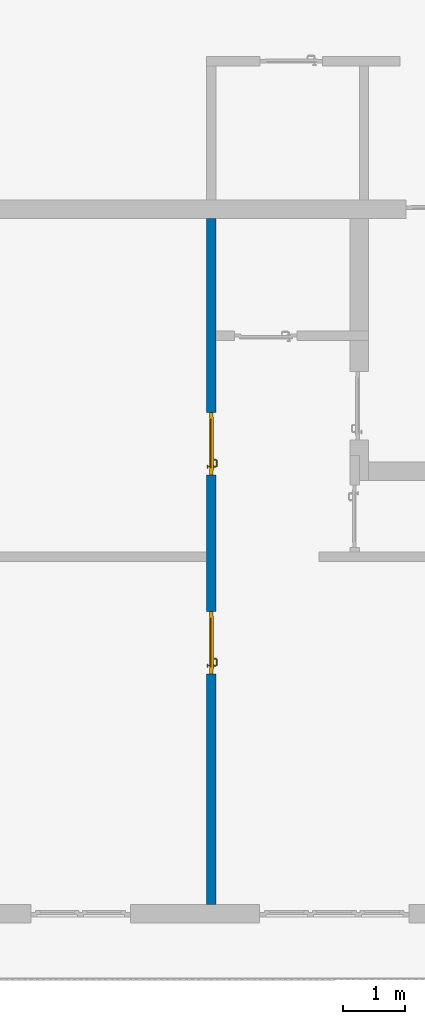
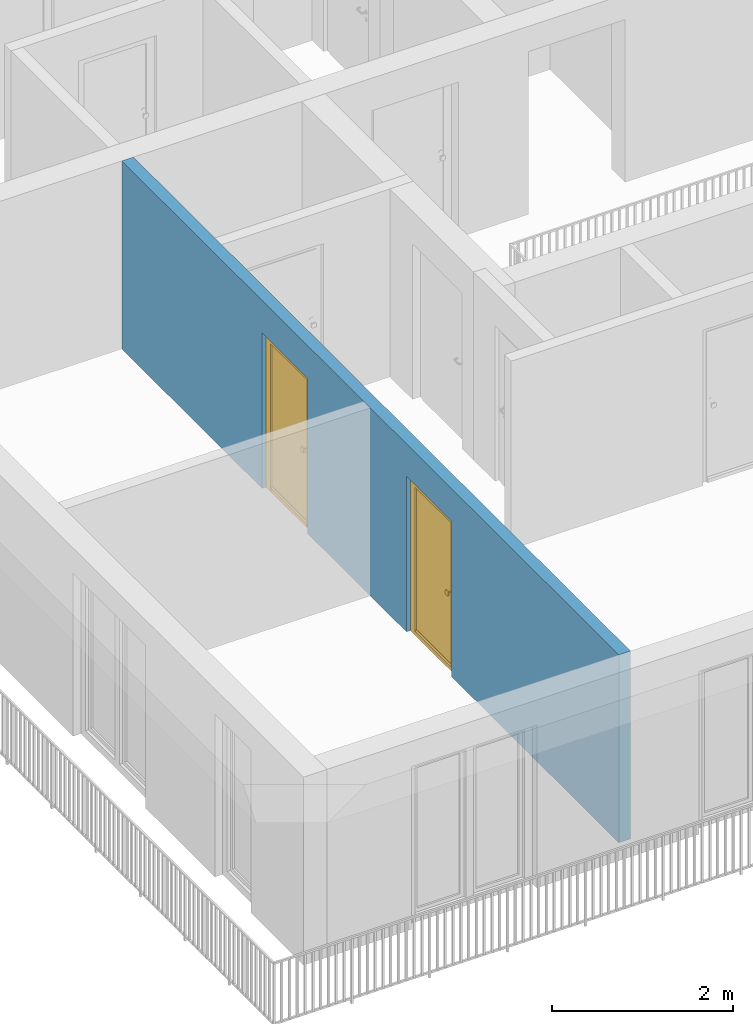
# One storey, part 8 of 54: 2 doors, 1 wall, 2 openings.
"""IFC4 building model written with IfcOpenShell, lengths in metres."""

from ifc_helpers import new_model, entity, si_unit, converted_unit, derived_unit, direction, frame, origin_with_axes, place, context, subcontext, project, spatial, polygons, source, transform, mapped, material, type_object, element, fill, save


model = new_model("IFC4")

# Units and contexts
model_context = context("Model", 3, precision=1e-05, world=origin_with_axes(), true_north=direction((0.0, 1.0)))
body_context = subcontext(model_context, "Body", "Model", "MODEL_VIEW")
ifc_project = project(units=[si_unit("LENGTHUNIT", "METRE"), si_unit("AREAUNIT", "SQUARE_METRE"), si_unit("VOLUMEUNIT", "CUBIC_METRE"), converted_unit("PLANEANGLEUNIT", "DEGREE", entity("IfcPlaneAngleMeasure", 0.0174532925199), si_unit("PLANEANGLEUNIT", "RADIAN"), dimensions=[0, 0, 0, 0, 0, 0, 0]), converted_unit("TIMEUNIT", "Year", entity("IfcTimeMeasure", 31556926.0), si_unit("TIMEUNIT", "SECOND"), dimensions=[0, 0, 1, 0, 0, 0, 0]), si_unit("MASSUNIT", "GRAM", prefix="KILO"), si_unit("THERMODYNAMICTEMPERATUREUNIT", "DEGREE_CELSIUS"), si_unit("LUMINOUSINTENSITYUNIT", "LUMEN"), si_unit("ENERGYUNIT", "JOULE", prefix="MEGA"), derived_unit("THERMALCONDUCTANCEUNIT", [(si_unit("POWERUNIT", "WATT"), 1), (si_unit("LENGTHUNIT", "METRE"), -1), (si_unit("THERMODYNAMICTEMPERATUREUNIT", "KELVIN"), -1)]), derived_unit("SPECIFICHEATCAPACITYUNIT", [(si_unit("ENERGYUNIT", "JOULE"), 1), (si_unit("MASSUNIT", "GRAM", prefix="KILO"), -1), (si_unit("THERMODYNAMICTEMPERATUREUNIT", "KELVIN"), -1)]), derived_unit("MASSDENSITYUNIT", [(si_unit("MASSUNIT", "GRAM", prefix="KILO"), 1), (si_unit("VOLUMEUNIT", "CUBIC_METRE"), -1)])], contexts=[model_context])

# Site, building, storey
site_placement = place(None, origin_with_axes())
site = spatial("IfcSite", under=ifc_project, at=site_placement, CompositionType="ELEMENT")
building_placement = place(site_placement, origin_with_axes())
building = spatial("IfcBuilding", under=site, at=building_placement, CompositionType="ELEMENT")
storey_placement = place(building_placement, frame((0.0, 0.0, 9.18), z_axis=(0.0, 0.0, 1.0), x_axis=(1.0, 0.0, 0.0)))
storey = spatial("IfcBuildingStorey", under=building, at=storey_placement, Name="3. Geschoss", CompositionType="ELEMENT", Elevation=9.18)

# Wall, openings, doors
ifc_material = material()
wall_type = type_object("IfcWallType", Name="150", PredefinedType="NOTDEFINED")
wall_placement = place(storey_placement, frame((-7.5421993804, 1.37118776896, 0.0), z_axis=(0.0, 0.0, 1.0), x_axis=(0.0, -1.0, 0.0)))
wall = element("IfcWall", 1, at=wall_placement, inside=storey, type_object=wall_type, material=ifc_material, Name="Wand-003", PredefinedType="NOTDEFINED", context=body_context, shape_type="Tessellation", body=[
    polygons([(7.3, 0.15, 0.0), (7.3, 0.15, 2.1), (6.3, 0.15, 2.1), (6.3, 0.15, 0.0), (4.1078818937, 0.15, 0.0), (4.1078818937, 0.15, 2.1), (3.1078818937, 0.15, 2.1), (3.1078818937, 0.15, 0.0), (0.0, 0.15, 0.0), (0.0, 0.15, 2.54), (11.0, 0.15, 2.54), (11.0, 0.15, 0.0), (7.3, 0.05, 0.0), (7.3, 0.0, 0.0), (7.3, 0.0, 2.1), (6.3, 0.0, 2.1), (6.3, 0.05, 0.0), (6.3, 0.0, 0.0), (4.1078818937, 0.0, 0.0), (4.1078818937, 0.0, 2.1), (3.1078818937, 0.0, 2.1), (3.1078818937, 0.0, 0.0), (0.0, 0.0, 0.0), (0.0, 0.0, 2.54), (11.0, 0.0, 2.54), (11.0, 0.0, 0.0)], [[[1, 2, 3, 4, 5, 6, 7, 8, 9, 10, 11, 12]], [[2, 1, 13, 14, 15]], [[3, 2, 15, 16]], [[17, 4, 3, 16, 18]], [[4, 17, 18, 19, 5]], [[19, 20, 6, 5]], [[20, 21, 7, 6]], [[21, 22, 8, 7]], [[23, 9, 8, 22]], [[23, 24, 10, 9]], [[25, 11, 10, 24]], [[12, 11, 25, 26]], [[13, 1, 12, 26, 14]], [[19, 18, 16, 15, 14, 26, 25, 24, 23, 22, 21, 20]]], closed=True),
])
opening_1_placement = place(wall_placement, frame((3.6078818937, 0.0, 0.0), z_axis=(0.0, 0.0, 1.0), x_axis=(1.0, 0.0, 0.0)))
opening_1 = element("IfcOpeningElement", 2, at=opening_1_placement, cuts=wall, context=body_context, identifier="Reference", shape_type="Tessellation", body=[
    polygons([(0.5, 0.05, 0.0), (0.5, 0.05, 2.1), (0.5, -0.001, 2.1), (0.5, -0.001, 0.0), (0.5, 0.151, 0.0), (0.5, 0.151, 2.1), (-0.5, 0.05, 2.1), (-0.5, -0.001, 2.1), (-0.5, 0.151, 2.1), (-0.5, -0.001, 0.0), (-0.5, 0.05, 0.0), (-0.5, 0.151, 0.0)], [[[1, 2, 3, 4]], [[2, 1, 5, 6]], [[7, 8, 3, 2, 6, 9]], [[8, 10, 4, 3]], [[1, 4, 10, 11, 12, 5]], [[6, 5, 12, 9]], [[7, 11, 10, 8]], [[11, 7, 9, 12]]], closed=True),
])
opening_2_placement = place(wall_placement, frame((6.8, 0.0, 0.0), z_axis=(0.0, 0.0, 1.0), x_axis=(1.0, 0.0, 0.0)))
opening_2 = element("IfcOpeningElement", 3, at=opening_2_placement, cuts=wall, context=body_context, identifier="Reference", shape_type="Tessellation", body=[
    polygons([(0.5, 0.05, 0.0), (0.5, 0.05, 2.1), (0.5, -0.001, 2.1), (0.5, -0.001, 0.0), (0.5, 0.151, 0.0), (0.5, 0.151, 2.1), (-0.5, 0.05, 2.1), (-0.5, -0.001, 2.1), (-0.5, 0.151, 2.1), (-0.5, -0.001, 0.0), (-0.5, 0.05, 0.0), (-0.5, 0.151, 0.0)], [[[1, 2, 3, 4]], [[2, 1, 5, 6]], [[7, 8, 3, 2, 6, 9]], [[8, 10, 4, 3]], [[1, 4, 10, 11, 12, 5]], [[6, 5, 12, 9]], [[7, 11, 10, 8]], [[11, 7, 9, 12]]], closed=True),
])
door_type = type_object("IfcDoorType", Name="Eingang 01 1-Fl 26", OperationType="SINGLE_SWING_LEFT", PredefinedType="DOOR")
shared_shape = source(origin_with_axes(), body_context, "Body", "Tessellation", [
    polygons([(-0.5, -0.05, 0.0), (-0.5, -0.05, 2.1), (-0.5, -0.03, 2.1), (-0.5, -0.03, 0.0), (-0.4, -0.05, 0.0), (-0.4, -0.05, 2.0), (-0.1301, -0.05, 2.0), (-0.0001, -0.05, 2.0), (0.4, -0.05, 2.0), (0.4, -0.05, 0.0), (0.5, -0.05, 0.0), (0.5, -0.05, 2.1), (0.5, -0.03, 2.1), (0.5, -0.03, 0.0), (0.4, -0.03, 0.0), (0.4, -0.03, 2.0), (-0.0001, -0.03, 2.0), (-0.1301, -0.03, 2.0), (-0.4, -0.03, 2.0), (-0.4, -0.03, 0.0)], [[[1, 2, 3, 4]], [[1, 5, 6, 7, 8, 9, 10, 11, 12, 2]], [[2, 12, 13, 3]], [[4, 3, 13, 14, 15, 16, 17, 18, 19, 20]], [[5, 1, 4, 20]], [[6, 5, 20, 19]], [[7, 6, 19, 18]], [[8, 7, 18, 17]], [[9, 8, 17, 16]], [[10, 9, 16, 15]], [[11, 10, 15, 14]], [[12, 11, 14, 13]]], closed=True),
    polygons([(-0.5, -0.03, 0.0), (-0.5, -0.03, 2.1), (-0.5, 0.0, 2.1), (-0.5, 0.0, 0.0), (-0.43, -0.03, 0.0), (-0.43, -0.03, 2.03), (-0.1001, -0.03, 2.03), (-0.0301, -0.03, 2.03), (0.43, -0.03, 2.03), (0.43, -0.03, 0.0), (0.5, -0.03, 0.0), (0.5, -0.03, 2.1), (0.5, 0.0, 2.1), (0.5, 0.0, 0.0), (0.43, 0.0, 0.0), (0.43, 0.0, 2.03), (-0.0301, 0.0, 2.03), (-0.1001, 0.0, 2.03), (-0.43, 0.0, 2.03), (-0.43, 0.0, 0.0)], [[[1, 2, 3, 4]], [[1, 5, 6, 7, 8, 9, 10, 11, 12, 2]], [[2, 12, 13, 3]], [[4, 3, 13, 14, 15, 16, 17, 18, 19, 20]], [[5, 1, 4, 20]], [[6, 5, 20, 19]], [[7, 6, 19, 18]], [[8, 7, 18, 17]], [[9, 8, 17, 16]], [[10, 9, 16, 15]], [[11, 10, 15, 14]], [[12, 11, 14, 13]]], closed=True),
    polygons([(-0.43, 0.01, 0.0), (-0.43, 0.01, 2.03), (0.43, 0.01, 2.03), (0.43, 0.01, 0.0), (-0.43, -0.03, 0.0), (-0.43, -0.03, 2.03), (0.43, -0.03, 2.03), (0.43, -0.03, 0.0)], [[[1, 2, 3, 4]], [[1, 5, 6, 2]], [[2, 6, 7, 3]], [[3, 7, 8, 4]], [[4, 8, 5, 1]], [[8, 7, 6, 5]]], closed=True),
    polygons([(-0.395, -0.05, 0.0), (0.395, -0.05, 0.0), (0.395, -0.05, 0.05), (-0.395, -0.05, 0.05), (-0.395, -0.03, 0.0), (0.395, -0.03, 0.0), (0.395, -0.03, 0.07), (0.395, -0.035, 0.07), (-0.395, -0.035, 0.07), (-0.395, -0.03, 0.07)], [[[1, 2, 3, 4]], [[5, 6, 2, 1]], [[2, 6, 7, 8, 3]], [[4, 3, 8, 9]], [[1, 4, 9, 10, 5]], [[10, 7, 6, 5]], [[9, 8, 7, 10]]], closed=True),
    polygons([(0.3835, 0.02, 1.0733826859), (0.37, 0.02, 1.077), (0.37, 0.0199, 1.077), (0.3835, 0.0199, 1.0733826859), (0.393382685902, 0.02, 1.0635), (0.397, 0.02, 1.05), (0.393382685902, 0.02, 1.0365), (0.3835, 0.02, 1.0266173141), (0.37, 0.02, 1.023), (0.3565, 0.02, 1.0266173141), (0.346617314098, 0.02, 1.0365), (0.343, 0.02, 1.05), (0.346617314098, 0.02, 1.0635), (0.3565, 0.02, 1.0733826859), (0.3565, 0.0199, 1.0733826859), (0.37, 0.0101, 1.077), (0.3835, 0.0101, 1.0733826859), (0.393382685902, 0.0199, 1.0635), (0.397, 0.0199, 1.05), (0.393382685902, 0.0199, 1.0365), (0.3835, 0.0199, 1.0266173141), (0.37, 0.0199, 1.023), (0.3565, 0.0199, 1.0266173141), (0.346617314098, 0.0199, 1.0365), (0.343, 0.0199, 1.05), (0.346617314098, 0.0199, 1.0635), (0.3565, 0.0101, 1.0733826859), (0.37, 0.01, 1.077), (0.3835, 0.01, 1.0733826859), (0.393382685902, 0.0101, 1.0635), (0.397, 0.0101, 1.05), (0.393382685902, 0.0101, 1.0365), (0.3835, 0.0101, 1.0266173141), (0.37, 0.0101, 1.023), (0.3565, 0.0101, 1.0266173141), (0.346617314098, 0.0101, 1.0365), (0.343, 0.0101, 1.05), (0.346617314098, 0.0101, 1.0635), (0.3565, 0.01, 1.0733826859), (0.346617314098, 0.01, 1.0635), (0.343, 0.01, 1.05), (0.346617314098, 0.01, 1.0365), (0.3565, 0.01, 1.0266173141), (0.37, 0.01, 1.023), (0.3835, 0.01, 1.0266173141), (0.393382685902, 0.01, 1.0365), (0.397, 0.01, 1.05), (0.393382685902, 0.01, 1.0635)], [[[1, 2, 3, 4]], [[2, 1, 5, 6, 7, 8, 9, 10, 11, 12, 13, 14]], [[2, 14, 15, 3]], [[4, 3, 16, 17]], [[5, 1, 4, 18]], [[6, 5, 18, 19]], [[7, 6, 19, 20]], [[8, 7, 20, 21]], [[9, 8, 21, 22]], [[10, 9, 22, 23]], [[11, 10, 23, 24]], [[12, 11, 24, 25]], [[13, 12, 25, 26]], [[14, 13, 26, 15]], [[3, 15, 27, 16]], [[17, 16, 28, 29]], [[18, 4, 17, 30]], [[19, 18, 30, 31]], [[20, 19, 31, 32]], [[21, 20, 32, 33]], [[22, 21, 33, 34]], [[23, 22, 34, 35]], [[24, 23, 35, 36]], [[25, 24, 36, 37]], [[26, 25, 37, 38]], [[15, 26, 38, 27]], [[16, 27, 39, 28]], [[28, 39, 40, 41, 42, 43, 44, 45, 46, 47, 48, 29]], [[30, 17, 29, 48]], [[31, 30, 48, 47]], [[32, 31, 47, 46]], [[33, 32, 46, 45]], [[34, 33, 45, 44]], [[35, 34, 44, 43]], [[36, 35, 43, 42]], [[37, 36, 42, 41]], [[38, 37, 41, 40]], [[27, 38, 40, 39]]], closed=True),
    polygons([(0.362532169224, 0.019, 0.959692280177), (0.363279754556, 0.019, 0.961639806549), (0.35705, 0.019, 0.972430057958), (0.347569942042, 0.019, 0.96295), (0.365, 0.019, 0.952886751346), (0.365, 0.019, 0.9544), (0.362532169224, 0.02, 0.959692280177), (0.363279754556, 0.02, 0.961639806549), (0.364624817685, 0.02, 0.965143815798), (0.364624817685, 0.019, 0.965143815798), (0.37, 0.019, 0.967425445323), (0.37, 0.019, 0.9759), (0.357, 0.019, 0.972516660498), (0.347483339502, 0.019, 0.963), (0.365, 0.019, 0.95), (0.3441, 0.019, 0.95), (0.365, 0.019, 0.947113248654), (0.365, 0.019, 0.941339745962), (0.365, 0.019, 0.9375), (0.365, 0.02, 0.9375), (0.365, 0.02, 0.941339745962), (0.365, 0.02, 0.947113248654), (0.365, 0.02, 0.95), (0.365, 0.02, 0.952886751346), (0.365, 0.02, 0.9544), (0.346703916638, 0.02, 0.96345), (0.35655, 0.02, 0.973296083362), (0.37, 0.02, 0.9769), (0.37, 0.02, 0.967425445323), (0.375375182315, 0.019, 0.965143815798), (0.376720245444, 0.019, 0.961639806549), (0.38295, 0.019, 0.972430057958), (0.37, 0.019, 0.976), (0.357, 0.0189, 0.972516660498), (0.347483339502, 0.0189, 0.963), (0.344, 0.019, 0.95), (0.347569942042, 0.019, 0.93705), (0.35705, 0.019, 0.927569942042), (0.37, 0.019, 0.9241), (0.37, 0.019, 0.9325), (0.366464466094, 0.019, 0.933964466094), (0.366464466094, 0.02, 0.933964466094), (0.37, 0.02, 0.9231), (0.35655, 0.02, 0.926703916638), (0.37, 0.02, 0.9325), (0.346703916638, 0.02, 0.93655), (0.3431, 0.02, 0.95), (0.346617314098, 0.02, 0.9635), (0.3565, 0.02, 0.973382685902), (0.37, 0.02, 0.977), (0.375375182315, 0.02, 0.965143815798), (0.38345, 0.02, 0.973296083362), (0.376720245444, 0.02, 0.961639806549), (0.377467830776, 0.02, 0.959692280177), (0.377467830776, 0.019, 0.959692280177), (0.375, 0.019, 0.9544), (0.375, 0.019, 0.952886751346), (0.392430057958, 0.019, 0.96295), (0.383, 0.019, 0.972516660498), (0.37, 0.0189, 0.976), (0.357, 0.0101, 0.972516660498), (0.347483339502, 0.0101, 0.963), (0.344, 0.0189, 0.95), (0.347483339502, 0.019, 0.937), (0.357, 0.019, 0.927483339502), (0.37, 0.019, 0.924), (0.38295, 0.019, 0.927569942042), (0.375, 0.019, 0.941339745962), (0.375, 0.019, 0.9375), (0.373535533906, 0.019, 0.933964466094), (0.37, 0.02, 0.923), (0.3565, 0.02, 0.926617314098), (0.38345, 0.02, 0.926703916638), (0.373535533906, 0.02, 0.933964466094), (0.375, 0.02, 0.9375), (0.375, 0.02, 0.941339745962), (0.346617314098, 0.02, 0.9365), (0.343, 0.02, 0.95), (0.346617314098, 0.0199, 0.9635), (0.3565, 0.0199, 0.973382685902), (0.37, 0.0199, 0.977), (0.3835, 0.02, 0.973382685902), (0.393296083362, 0.02, 0.96345), (0.375, 0.02, 0.952886751346), (0.375, 0.02, 0.9544), (0.375, 0.02, 0.95), (0.375, 0.02, 0.947113248654), (0.375, 0.019, 0.947113248654), (0.375, 0.019, 0.95), (0.3959, 0.019, 0.95), (0.392516660498, 0.019, 0.963), (0.383, 0.0189, 0.972516660498), (0.37, 0.0101, 0.976), (0.357, 0.01, 0.972516660498), (0.347483339502, 0.01, 0.963), (0.344, 0.0101, 0.95), (0.347483339502, 0.0189, 0.937), (0.357, 0.0189, 0.927483339502), (0.37, 0.0189, 0.924), (0.383, 0.019, 0.927483339502), (0.392430057958, 0.019, 0.93705), (0.37, 0.0199, 0.923), (0.3565, 0.0199, 0.926617314098), (0.3835, 0.02, 0.926617314098), (0.393296083362, 0.02, 0.93655), (0.346617314098, 0.0199, 0.9365), (0.343, 0.0199, 0.95), (0.346617314098, 0.0101, 0.9635), (0.3565, 0.0101, 0.973382685902), (0.37, 0.0101, 0.977), (0.3835, 0.0199, 0.973382685902), (0.393382685902, 0.02, 0.9635), (0.3969, 0.02, 0.95), (0.396, 0.019, 0.95), (0.392516660498, 0.0189, 0.963), (0.383, 0.0101, 0.972516660498), (0.37, 0.01, 0.976), (0.35695, 0.01, 0.972603263039), (0.347396736961, 0.01, 0.96305), (0.344, 0.01, 0.95), (0.347483339502, 0.0101, 0.937), (0.357, 0.0101, 0.927483339502), (0.37, 0.0101, 0.924), (0.383, 0.0189, 0.927483339502), (0.392516660498, 0.019, 0.937), (0.37, 0.0101, 0.923), (0.3565, 0.0101, 0.926617314098), (0.3835, 0.0199, 0.926617314098), (0.393382685902, 0.02, 0.9365), (0.346617314098, 0.0101, 0.9365), (0.343, 0.0101, 0.95), (0.346617314098, 0.01, 0.9635), (0.3565, 0.01, 0.973382685902), (0.37, 0.01, 0.977), (0.3835, 0.0101, 0.973382685902), (0.393382685902, 0.0199, 0.9635), (0.397, 0.02, 0.95), (0.396, 0.0189, 0.95), (0.392516660498, 0.0101, 0.963), (0.383, 0.01, 0.972516660498), (0.37, 0.01, 0.9761), (0.35655, 0.01, 0.973296083362), (0.346703916638, 0.01, 0.96345), (0.3439, 0.01, 0.95), (0.347483339502, 0.01, 0.937), (0.357, 0.01, 0.927483339502), (0.37, 0.01, 0.924), (0.383, 0.0101, 0.927483339502), (0.392516660498, 0.0189, 0.937), (0.37, 0.01, 0.923), (0.3565, 0.01, 0.926617314098), (0.3835, 0.0101, 0.926617314098), (0.393382685902, 0.0199, 0.9365), (0.346617314098, 0.01, 0.9365), (0.343, 0.01, 0.95), (0.37, 0.01, 0.9769), (0.3835, 0.01, 0.973382685902), (0.393382685902, 0.0101, 0.9635), (0.397, 0.0199, 0.95), (0.396, 0.0101, 0.95), (0.392516660498, 0.01, 0.963), (0.38305, 0.01, 0.972603263039), (0.3431, 0.01, 0.95), (0.347396736961, 0.01, 0.93695), (0.35695, 0.01, 0.927396736961), (0.37, 0.01, 0.9239), (0.383, 0.01, 0.927483339502), (0.392516660498, 0.0101, 0.937), (0.37, 0.01, 0.9231), (0.35655, 0.01, 0.926703916638), (0.3835, 0.01, 0.926617314098), (0.393382685902, 0.0101, 0.9365), (0.346703916638, 0.01, 0.93655), (0.38345, 0.01, 0.973296083362), (0.393382685902, 0.01, 0.9635), (0.397, 0.0101, 0.95), (0.396, 0.01, 0.95), (0.392603263039, 0.01, 0.96305), (0.38305, 0.01, 0.927396736961), (0.392516660498, 0.01, 0.937), (0.38345, 0.01, 0.926703916638), (0.393382685902, 0.01, 0.9365), (0.393296083362, 0.01, 0.96345), (0.397, 0.01, 0.95), (0.3961, 0.01, 0.95), (0.392603263039, 0.01, 0.93695), (0.393296083362, 0.01, 0.93655), (0.3969, 0.01, 0.95)], [[[1, 2, 3, 4, 5, 6]], [[1, 7, 8, 9, 10, 2]], [[10, 11, 12, 3, 2]], [[4, 3, 13, 14]], [[15, 5, 4, 16]], [[6, 5, 15, 17, 18, 19, 20, 21, 22, 23, 24, 25]], [[6, 25, 7, 1]], [[7, 25, 24, 26, 27, 8]], [[9, 8, 27, 28, 29]], [[10, 9, 29, 11]], [[30, 31, 32, 12, 11]], [[3, 12, 33, 13]], [[14, 13, 34, 35]], [[16, 4, 14, 36]], [[17, 15, 16, 37]], [[18, 17, 37, 38]], [[38, 39, 40, 41, 19, 18]], [[19, 41, 42, 20]], [[43, 44, 21, 20, 42, 45]], [[22, 21, 44, 46]], [[23, 22, 46, 47]], [[24, 23, 47, 26]], [[48, 49, 27, 26]], [[49, 50, 28, 27]], [[51, 29, 28, 52, 53]], [[11, 29, 51, 30]], [[30, 51, 53, 54, 55, 31]], [[55, 56, 57, 58, 32, 31]], [[12, 32, 59, 33]], [[13, 33, 60, 34]], [[35, 34, 61, 62]], [[36, 14, 35, 63]], [[37, 16, 36, 64]], [[38, 37, 64, 65]], [[39, 38, 65, 66]], [[39, 67, 68, 69, 70, 40]], [[41, 40, 45, 42]], [[71, 72, 44, 43]], [[73, 43, 45, 74, 75, 76]], [[72, 77, 46, 44]], [[77, 78, 47, 46]], [[78, 48, 26, 47]], [[79, 80, 49, 48]], [[80, 81, 50, 49]], [[50, 82, 52, 28]], [[54, 53, 52, 83, 84, 85]], [[55, 54, 85, 56]], [[85, 84, 86, 87, 76, 75, 69, 68, 88, 89, 57, 56]], [[57, 89, 90, 58]], [[32, 58, 91, 59]], [[33, 59, 92, 60]], [[34, 60, 93, 61]], [[62, 61, 94, 95]], [[63, 35, 62, 96]], [[64, 36, 63, 97]], [[65, 64, 97, 98]], [[66, 65, 98, 99]], [[67, 39, 66, 100]], [[88, 68, 67, 101]], [[70, 69, 75, 74]], [[40, 70, 74, 45]], [[102, 103, 72, 71]], [[104, 71, 43, 73]], [[76, 87, 105, 73]], [[103, 106, 77, 72]], [[106, 107, 78, 77]], [[107, 79, 48, 78]], [[108, 109, 80, 79]], [[109, 110, 81, 80]], [[81, 111, 82, 50]], [[82, 112, 83, 52]], [[86, 84, 83, 113]], [[87, 86, 113, 105]], [[89, 88, 101, 90]], [[58, 90, 114, 91]], [[59, 91, 115, 92]], [[60, 92, 116, 93]], [[61, 93, 117, 94]], [[95, 94, 118, 119]], [[96, 62, 95, 120]], [[97, 63, 96, 121]], [[98, 97, 121, 122]], [[99, 98, 122, 123]], [[100, 66, 99, 124]], [[101, 67, 100, 125]], [[126, 127, 103, 102]], [[128, 102, 71, 104]], [[129, 104, 73, 105]], [[127, 130, 106, 103]], [[130, 131, 107, 106]], [[131, 108, 79, 107]], [[132, 133, 109, 108]], [[133, 134, 110, 109]], [[110, 135, 111, 81]], [[111, 136, 112, 82]], [[112, 137, 113, 83]], [[137, 129, 105, 113]], [[90, 101, 125, 114]], [[91, 114, 138, 115]], [[92, 115, 139, 116]], [[93, 116, 140, 117]], [[94, 117, 141, 118]], [[119, 118, 142, 143]], [[120, 95, 119, 144]], [[121, 96, 120, 145]], [[122, 121, 145, 146]], [[123, 122, 146, 147]], [[124, 99, 123, 148]], [[125, 100, 124, 149]], [[150, 151, 127, 126]], [[152, 126, 102, 128]], [[153, 128, 104, 129]], [[151, 154, 130, 127]], [[154, 155, 131, 130]], [[155, 132, 108, 131]], [[143, 142, 133, 132]], [[142, 156, 134, 133]], [[134, 157, 135, 110]], [[135, 158, 136, 111]], [[136, 159, 137, 112]], [[159, 153, 129, 137]], [[114, 125, 149, 138]], [[115, 138, 160, 139]], [[116, 139, 161, 140]], [[117, 140, 162, 141]], [[118, 141, 156, 142]], [[144, 119, 143, 163]], [[145, 120, 144, 164]], [[146, 145, 164, 165]], [[147, 146, 165, 166]], [[148, 123, 147, 167]], [[149, 124, 148, 168]], [[169, 170, 151, 150]], [[171, 150, 126, 152]], [[172, 152, 128, 153]], [[170, 173, 154, 151]], [[173, 163, 155, 154]], [[163, 143, 132, 155]], [[156, 174, 157, 134]], [[157, 175, 158, 135]], [[158, 176, 159, 136]], [[176, 172, 153, 159]], [[138, 149, 168, 160]], [[139, 160, 177, 161]], [[140, 161, 178, 162]], [[141, 162, 174, 156]], [[164, 144, 163, 173]], [[165, 164, 173, 170]], [[166, 165, 170, 169]], [[167, 147, 166, 179]], [[168, 148, 167, 180]], [[181, 169, 150, 171]], [[182, 171, 152, 172]], [[174, 183, 175, 157]], [[175, 184, 176, 158]], [[184, 182, 172, 176]], [[160, 168, 180, 177]], [[161, 177, 185, 178]], [[162, 178, 183, 174]], [[179, 166, 169, 181]], [[180, 167, 179, 186]], [[187, 181, 171, 182]], [[183, 188, 184, 175]], [[188, 187, 182, 184]], [[177, 180, 186, 185]], [[178, 185, 188, 183]], [[186, 179, 181, 187]], [[185, 186, 187, 188]]], closed=True),
    polygons([(0.38, 0.02, 1.05), (0.377071067812, 0.02, 1.04292893219), (0.377071067812, 0.050696439392, 1.04292893219), (0.38, 0.0509849140336, 1.05), (0.37, 0.02, 1.04), (0.37, 0.05, 1.04), (0.375518993221, 0.0584992452783, 1.04292893219), (0.378277987014, 0.0596420579258, 1.05), (0.377071067812, 0.02, 1.05707106781), (0.377071067812, 0.050696439392, 1.05707106781), (0.362928932188, 0.02, 1.04292893219), (0.362928932188, 0.049303560608, 1.04292893219), (0.368858192988, 0.0557402514855, 1.04), (0.370704557509, 0.0657045575088, 1.04292893219), (0.372816199938, 0.0678161999379, 1.05), (0.375518993221, 0.0584992452783, 1.05707106781), (0.37, 0.02, 1.06), (0.37, 0.05, 1.06), (0.36, 0.02, 1.05), (0.36, 0.0490150859664, 1.05), (0.362197392755, 0.0529812576926, 1.04292893219), (0.365606601718, 0.0606066017178, 1.04), (0.363499245278, 0.0705189932208, 1.04292893219), (0.364642057926, 0.0732779870137, 1.05), (0.370704557509, 0.0657045575088, 1.05707106781), (0.368858192988, 0.0557402514855, 1.06), (0.362928932188, 0.02, 1.05707106781), (0.362928932188, 0.049303560608, 1.05707106781), (0.359438398962, 0.0518384450452, 1.05), (0.360508645927, 0.0555086459268, 1.04292893219), (0.360740251485, 0.0638581929877, 1.04), (0.355696439392, 0.0720710678119, 1.04292893219), (0.355984914034, 0.075, 1.05), (0.363499245278, 0.0705189932208, 1.05707106781), (0.365606601718, 0.0606066017178, 1.06), (0.362197392755, 0.0529812576926, 1.05707106781), (0.358397003498, 0.0533970034977, 1.05), (0.357981257693, 0.0571973927545, 1.04292893219), (0.355, 0.065, 1.04), (0.274303560608, 0.0720710678119, 1.04292893219), (0.274015085966, 0.075, 1.05), (0.355696439392, 0.0720710678119, 1.05707106781), (0.360740251485, 0.0638581929877, 1.06), (0.360508645927, 0.0555086459268, 1.05707106781), (0.356838445045, 0.0544383989617, 1.05), (0.354303560608, 0.0579289321881, 1.04292893219), (0.275, 0.065, 1.04), (0.266500754722, 0.0705189932208, 1.04292893219), (0.265357942074, 0.0732779870137, 1.05), (0.274303560608, 0.0720710678119, 1.05707106781), (0.355, 0.065, 1.06), (0.357981257693, 0.0571973927545, 1.05707106781), (0.354015085966, 0.055, 1.05), (0.275696439392, 0.0579289321881, 1.04292893219), (0.269259748515, 0.0638581929877, 1.04), (0.259295442491, 0.0657045575088, 1.04292893219), (0.257183800062, 0.0678161999379, 1.05), (0.266500754722, 0.0705189932208, 1.05707106781), (0.275, 0.065, 1.06), (0.354303560608, 0.0579289321881, 1.05707106781), (0.275984914034, 0.055, 1.05), (0.272018742307, 0.0571973927545, 1.04292893219), (0.264393398282, 0.0606066017178, 1.04), (0.254481006779, 0.0584992452783, 1.04292893219), (0.251722012986, 0.0596420579258, 1.05), (0.259295442491, 0.0657045575088, 1.05707106781), (0.269259748515, 0.0638581929877, 1.06), (0.275696439392, 0.0579289321881, 1.05707106781), (0.273161554955, 0.0544383989617, 1.05), (0.269491354073, 0.0555086459268, 1.04292893219), (0.261141807012, 0.0557402514855, 1.04), (0.252928932188, 0.050696439392, 1.04292893219), (0.25, 0.0509849140336, 1.05), (0.254481006779, 0.0584992452783, 1.05707106781), (0.264393398282, 0.0606066017178, 1.06), (0.272018742307, 0.0571973927545, 1.05707106781), (0.271602996502, 0.0533970034977, 1.05), (0.267802607245, 0.0529812576926, 1.04292893219), (0.26, 0.05, 1.04), (0.252928932188, 0.02, 1.04292893219), (0.25, 0.02, 1.05), (0.252928932188, 0.050696439392, 1.05707106781), (0.261141807012, 0.0557402514855, 1.06), (0.269491354073, 0.0555086459268, 1.05707106781), (0.270561601038, 0.0518384450452, 1.05), (0.267071067812, 0.049303560608, 1.04292893219), (0.26, 0.02, 1.04), (0.267071067812, 0.02, 1.04292893219), (0.27, 0.02, 1.05), (0.267071067812, 0.02, 1.05707106781), (0.26, 0.02, 1.06), (0.252928932188, 0.02, 1.05707106781), (0.26, 0.05, 1.06), (0.267802607245, 0.0529812576926, 1.05707106781), (0.27, 0.0490150859664, 1.05), (0.267071067812, 0.049303560608, 1.05707106781)], [[[1, 2, 3, 4]], [[2, 5, 6, 3]], [[4, 3, 7, 8]], [[9, 1, 4, 10]], [[5, 11, 12, 6]], [[3, 6, 13, 7]], [[8, 7, 14, 15]], [[10, 4, 8, 16]], [[17, 9, 10, 18]], [[11, 19, 20, 12]], [[6, 12, 21, 13]], [[7, 13, 22, 14]], [[15, 14, 23, 24]], [[16, 8, 15, 25]], [[18, 10, 16, 26]], [[27, 17, 18, 28]], [[19, 27, 28, 20]], [[12, 20, 29, 21]], [[13, 21, 30, 22]], [[14, 22, 31, 23]], [[24, 23, 32, 33]], [[25, 15, 24, 34]], [[26, 16, 25, 35]], [[28, 18, 26, 36]], [[20, 28, 36, 29]], [[21, 29, 37, 30]], [[22, 30, 38, 31]], [[23, 31, 39, 32]], [[33, 32, 40, 41]], [[34, 24, 33, 42]], [[35, 25, 34, 43]], [[36, 26, 35, 44]], [[29, 36, 44, 37]], [[30, 37, 45, 38]], [[31, 38, 46, 39]], [[32, 39, 47, 40]], [[41, 40, 48, 49]], [[42, 33, 41, 50]], [[43, 34, 42, 51]], [[44, 35, 43, 52]], [[37, 44, 52, 45]], [[38, 45, 53, 46]], [[39, 46, 54, 47]], [[40, 47, 55, 48]], [[49, 48, 56, 57]], [[50, 41, 49, 58]], [[51, 42, 50, 59]], [[52, 43, 51, 60]], [[45, 52, 60, 53]], [[46, 53, 61, 54]], [[47, 54, 62, 55]], [[48, 55, 63, 56]], [[57, 56, 64, 65]], [[58, 49, 57, 66]], [[59, 50, 58, 67]], [[60, 51, 59, 68]], [[53, 60, 68, 61]], [[54, 61, 69, 62]], [[55, 62, 70, 63]], [[56, 63, 71, 64]], [[65, 64, 72, 73]], [[66, 57, 65, 74]], [[67, 58, 66, 75]], [[68, 59, 67, 76]], [[61, 68, 76, 69]], [[62, 69, 77, 70]], [[63, 70, 78, 71]], [[64, 71, 79, 72]], [[73, 72, 80, 81]], [[74, 65, 73, 82]], [[75, 66, 74, 83]], [[76, 67, 75, 84]], [[69, 76, 84, 77]], [[70, 77, 85, 78]], [[71, 78, 86, 79]], [[72, 79, 87, 80]], [[81, 80, 87, 88, 89, 90, 91, 92]], [[82, 73, 81, 92]], [[83, 74, 82, 93]], [[84, 75, 83, 94]], [[77, 84, 94, 85]], [[78, 85, 95, 86]], [[79, 86, 88, 87]], [[86, 95, 89, 88]], [[95, 96, 90, 89]], [[96, 93, 91, 90]], [[93, 82, 92, 91]], [[94, 83, 93, 96]], [[85, 94, 96, 95]]], closed=False),
    polygons([(0.364696699141, -0.035, 1.04469669914), (0.3625, -0.035, 1.05), (0.364696699141, -0.035, 1.05530330086), (0.37, -0.035, 1.0575), (0.375303300859, -0.035, 1.05530330086), (0.3775, -0.035, 1.05), (0.375303300859, -0.035, 1.04469669914), (0.37, -0.035, 1.0425), (0.364696699141, -0.075, 1.04469669914), (0.3625, -0.075, 1.05), (0.364696699141, -0.075, 1.05530330086), (0.37, -0.075, 1.0575), (0.375303300859, -0.075, 1.05530330086), (0.3775, -0.075, 1.05), (0.375303300859, -0.075, 1.04469669914), (0.37, -0.075, 1.0425)], [[[1, 2, 3, 4, 5, 6, 7, 8]], [[1, 9, 10, 2]], [[2, 10, 11, 3]], [[3, 11, 12, 4]], [[4, 12, 13, 5]], [[5, 13, 14, 6]], [[6, 14, 15, 7]], [[7, 15, 16, 8]], [[8, 16, 9, 1]], [[9, 16, 15, 14, 13, 12, 11, 10]]], closed=True),
    polygons([(0.395, -0.03, 0.975), (0.395, -0.035, 0.975), (0.393096988313, -0.035, 0.965432914191), (0.393096988313, -0.03, 0.965432914191), (0.395, -0.03, 1.1), (0.395, -0.035, 1.1), (0.393096988313, -0.035, 1.10956708581), (0.38767766953, -0.035, 1.11767766953), (0.379567085809, -0.035, 1.12309698831), (0.37, -0.035, 1.125), (0.360432914191, -0.035, 1.12309698831), (0.35232233047, -0.035, 1.11767766953), (0.346903011687, -0.035, 1.10956708581), (0.345, -0.035, 1.1), (0.345, -0.035, 0.975), (0.346903011687, -0.035, 0.965432914191), (0.35232233047, -0.035, 0.95732233047), (0.360432914191, -0.035, 0.951903011687), (0.37, -0.035, 0.95), (0.379567085809, -0.035, 0.951903011687), (0.38767766953, -0.035, 0.95732233047), (0.38767766953, -0.03, 0.95732233047), (0.379567085809, -0.03, 0.951903011687), (0.37, -0.03, 0.95), (0.360432914191, -0.03, 0.951903011687), (0.35232233047, -0.03, 0.95732233047), (0.346903011687, -0.03, 0.965432914191), (0.345, -0.03, 0.975), (0.345, -0.03, 1.1), (0.346903011687, -0.03, 1.10956708581), (0.35232233047, -0.03, 1.11767766953), (0.360432914191, -0.03, 1.12309698831), (0.37, -0.03, 1.125), (0.379567085809, -0.03, 1.12309698831), (0.38767766953, -0.03, 1.11767766953), (0.393096988313, -0.03, 1.10956708581)], [[[1, 2, 3, 4]], [[5, 6, 2, 1]], [[2, 6, 7, 8, 9, 10, 11, 12, 13, 14, 15, 16, 17, 18, 19, 20, 21, 3]], [[4, 3, 21, 22]], [[1, 4, 22, 23, 24, 25, 26, 27, 28, 29, 30, 31, 32, 33, 34, 35, 36, 5]], [[36, 7, 6, 5]], [[35, 8, 7, 36]], [[34, 9, 8, 35]], [[33, 10, 9, 34]], [[32, 11, 10, 33]], [[31, 12, 11, 32]], [[30, 13, 12, 31]], [[29, 14, 13, 30]], [[28, 15, 14, 29]], [[27, 16, 15, 28]], [[26, 17, 16, 27]], [[25, 18, 17, 26]], [[24, 19, 18, 25]], [[23, 20, 19, 24]], [[22, 21, 20, 23]]], closed=True),
    polygons([(0.39, -0.075, 1.08), (0.39, -0.09, 1.08), (0.395, -0.09, 1.07866025404), (0.395, -0.075, 1.07866025404), (0.35, -0.075, 1.08), (0.35, -0.09, 1.08), (0.345, -0.09, 1.07866025404), (0.341339745962, -0.09, 1.075), (0.34, -0.09, 1.07), (0.34, -0.09, 1.03), (0.341339745962, -0.09, 1.025), (0.345, -0.09, 1.02133974596), (0.35, -0.09, 1.02), (0.39, -0.09, 1.02), (0.395, -0.09, 1.02133974596), (0.398660254038, -0.09, 1.025), (0.4, -0.09, 1.03), (0.4, -0.09, 1.07), (0.398660254038, -0.09, 1.075), (0.398660254038, -0.075, 1.075), (0.4, -0.075, 1.07), (0.4, -0.075, 1.03), (0.398660254038, -0.075, 1.025), (0.395, -0.075, 1.02133974596), (0.39, -0.075, 1.02), (0.35, -0.075, 1.02), (0.345, -0.075, 1.02133974596), (0.341339745962, -0.075, 1.025), (0.34, -0.075, 1.03), (0.34, -0.075, 1.07), (0.341339745962, -0.075, 1.075), (0.345, -0.075, 1.07866025404)], [[[1, 2, 3, 4]], [[5, 6, 2, 1]], [[2, 6, 7, 8, 9, 10, 11, 12, 13, 14, 15, 16, 17, 18, 19, 3]], [[4, 3, 19, 20]], [[1, 4, 20, 21, 22, 23, 24, 25, 26, 27, 28, 29, 30, 31, 32, 5]], [[32, 7, 6, 5]], [[31, 8, 7, 32]], [[30, 9, 8, 31]], [[29, 10, 9, 30]], [[28, 11, 10, 29]], [[27, 12, 11, 28]], [[26, 13, 12, 27]], [[25, 14, 13, 26]], [[24, 15, 14, 25]], [[23, 16, 15, 24]], [[22, 17, 16, 23]], [[21, 18, 17, 22]], [[20, 19, 18, 21]]], closed=True),
])
door_1_placement = place(opening_1_placement, frame((-0.4, 0.0, 0.0), z_axis=(0.0, 0.0, 1.0), x_axis=(1.0, 0.0, 0.0)))
door_1 = element("IfcDoor", 4, at=door_1_placement, inside=storey, type_object=door_type, OverallHeight=2.1, OverallWidth=1.0, PredefinedType="DOOR", context=body_context, shape_type="MappedRepresentation", body=[
    mapped(shared_shape, transform((0.4, 0.1, 0.0))),
])
fill(opening_1, door_1)
door_2_placement = place(opening_2_placement, frame((-0.4, 0.0, 0.0), z_axis=(0.0, 0.0, 1.0), x_axis=(1.0, 0.0, 0.0)))
door_2 = element("IfcDoor", 5, at=door_2_placement, inside=storey, type_object=door_type, OverallHeight=2.1, OverallWidth=1.0, PredefinedType="DOOR", context=body_context, shape_type="MappedRepresentation", body=[
    mapped(shared_shape, transform((0.4, 0.1, 0.0))),
])
fill(opening_2, door_2)

save(model, "model.ifc")
